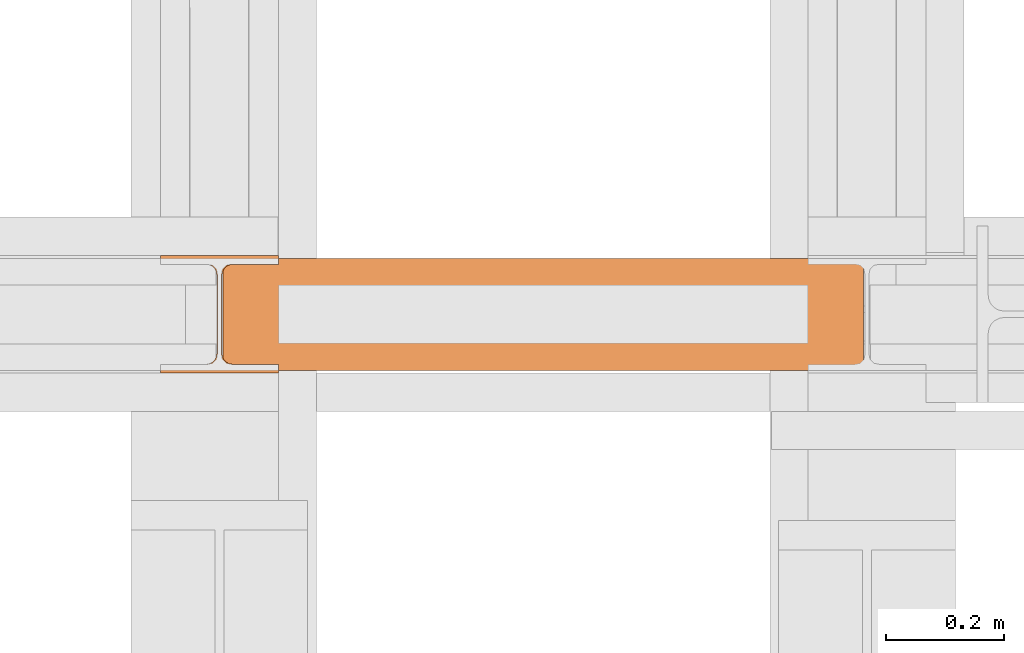
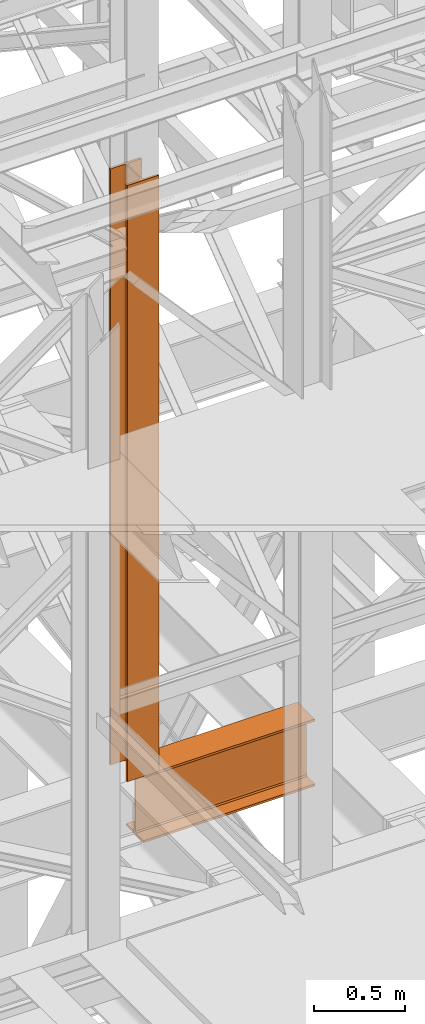
# One storey, part 113 of 208: 2 proxies.
"""IFC2X3 building model written with IfcOpenShell, lengths in millimetres."""

from ifc_helpers import new_model, entity, si_unit, converted_unit, frame, origin, origin_with_axes, place, context, subcontext, project, spatial, faceted_brep, element, save


model = new_model("IFC2X3")

# Units and contexts
model_context = context("Model", 3, precision=1e-05, world=origin())
plan_context = context("Plan", 3, precision=1e-05, world=origin())
body_context = subcontext(model_context, "Body", "Model", "MODEL_VIEW")
ifc_project = project(units=[si_unit("LENGTHUNIT", "METRE", prefix="MILLI"), converted_unit("PLANEANGLEUNIT", "DEGREE", entity("IfcPlaneAngleMeasure", 0.0174532925199433), si_unit("PLANEANGLEUNIT", "RADIAN"), dimensions=[0, 0, 0, 0, 0, 0, 0]), si_unit("AREAUNIT", "SQUARE_METRE"), si_unit("VOLUMEUNIT", "CUBIC_METRE")], contexts=[model_context, plan_context])

# Building, storey
building_placement = place(None, origin())
building = spatial("IfcBuilding", under=ifc_project, at=building_placement, CompositionType="COMPLEX")
storey_placement = place(building_placement, origin_with_axes())
storey = spatial("IfcBuildingStorey", under=building, at=storey_placement, Name="Geschoss", CompositionType="ELEMENT")

# Proxies
proxy_1_placement = place(storey_placement, frame((2199.254968580824, -16057.57439657637, 4834.989987483023), z_axis=(0.0, 0.0, 1.0), x_axis=(1.0, 0.0, 0.0)))
element("IfcBuildingElementProxy", 1, at=proxy_1_placement, inside=storey, context=body_context, shape_type="Brep", body=[
    faceted_brep([(1088.009999895696, 0.01000000000021828, 450.0100178813937), (1088.009999895696, 190.0100125169756, 450.0100178813937), (1088.009999895696, 190.0100125169756, 435.4100240564349), (1088.009999895696, 120.7100073045494, 435.4100091552737), (1088.009999895696, 109.841562265754, 433.2347078418734), (1088.009999895696, 101.8853126263621, 425.2784563398363), (1088.009999895696, 99.71000619068764, 414.4100113010409), (1088.009999895696, 99.71000619068764, 35.60999167919181), (1088.009999895696, 101.8853126263621, 24.74154664039634), (1088.009999895696, 109.841562265754, 16.78529513835929), (1088.009999895696, 120.7100073045494, 14.60999382495902), (1088.009999895696, 190.0100125169756, 14.60999382495902), (1088.009999895696, 190.0100125169756, 0.01000000000021828), (1088.009999895696, 0.01000000000021828, 0.01000000000021828), (1088.009999895696, 0.01000000000021828, 14.60999382495902), (1088.009999895696, 69.3100052124264, 14.60999382495902), (1088.009999895696, 80.17845025122188, 16.78529513835929), (1088.009999895696, 88.13469989061377, 24.74154664039634), (1088.009999895696, 90.3100063262882, 35.60999167919181), (1088.009999895696, 90.3100063262882, 414.4100113010409), (1088.009999895696, 88.13469989061377, 425.2784563398363), (1088.009999895696, 80.17845025122188, 433.2347078418734), (1088.009999895696, 69.3100052124264, 435.4100091552737), (1088.009999895696, 0.01000000000021828, 435.4100240564349), (1088.009999895696, 190.0100125169756, 450.0100178813937), (1088.009999895696, 0.01000000000021828, 450.0100178813937), (0.01000000000021828, 0.01000000000021828, 450.0100178813937), (0.01000000000021828, 190.0100125169756, 450.0100178813937), (1088.009999895696, 190.0100125169756, 435.4100240564349), (1088.009999895696, 190.0100125169756, 450.0100178813937), (0.01000000000021828, 190.0100125169756, 450.0100178813937), (0.01000000000021828, 190.0100125169756, 435.4100240564349), (1088.009999895696, 120.7100073045494, 435.4100091552737), (1088.009999895696, 190.0100125169756, 435.4100240564349), (0.01000000000021828, 190.0100125169756, 435.4100240564349), (0.01000000000021828, 120.7100073045494, 435.4100091552737), (1088.009999895696, 109.841562265754, 433.2347078418734), (1088.009999895696, 120.7100073045494, 435.4100091552737), (0.01000000000021828, 120.7100073045494, 435.4100091552737), (0.01000000000021828, 109.841562265754, 433.2347078418734), (1088.009999895696, 101.8853126263621, 425.2784563398363), (1088.009999895696, 109.841562265754, 433.2347078418734), (0.01000000000021828, 109.841562265754, 433.2347078418734), (0.01000000000021828, 101.8853126263621, 425.2784563398363), (1088.009999895696, 99.71000619068764, 414.4100113010409), (1088.009999895696, 101.8853126263621, 425.2784563398363), (0.01000000000021828, 101.8853126263621, 425.2784563398363), (0.01000000000021828, 99.71000619068764, 414.4100113010409), (1088.009999895696, 99.71000619068764, 35.60999167919181), (1088.009999895696, 99.71000619068764, 414.4100113010409), (0.01000000000021828, 99.71000619068764, 414.4100113010409), (0.01000000000021828, 99.71000619068764, 35.60999167919181), (1088.009999895696, 101.8853126263621, 24.74154664039634), (1088.009999895696, 99.71000619068764, 35.60999167919181), (0.01000000000021828, 99.71000619068764, 35.60999167919181), (0.01000000000021828, 101.8853126263621, 24.74154664039634), (1088.009999895696, 109.841562265754, 16.78529513835929), (1088.009999895696, 101.8853126263621, 24.74154664039634), (0.01000000000021828, 101.8853126263621, 24.74154664039634), (0.01000000000021828, 109.841562265754, 16.78529513835929), (1088.009999895696, 120.7100073045494, 14.60999382495902), (1088.009999895696, 109.841562265754, 16.78529513835929), (0.01000000000021828, 109.841562265754, 16.78529513835929), (0.01000000000021828, 120.7100073045494, 14.60999382495902), (1088.009999895696, 190.0100125169756, 14.60999382495902), (1088.009999895696, 120.7100073045494, 14.60999382495902), (0.01000000000021828, 120.7100073045494, 14.60999382495902), (0.01000000000021828, 190.0100125169756, 14.60999382495902), (1088.009999895696, 190.0100125169756, 0.01000000000021828), (1088.009999895696, 190.0100125169756, 14.60999382495902), (0.01000000000021828, 190.0100125169756, 14.60999382495902), (0.01000000000021828, 190.0100125169756, 0.01000000000021828), (1088.009999895696, 0.01000000000021828, 0.01000000000021828), (1088.009999895696, 190.0100125169756, 0.01000000000021828), (0.01000000000021828, 190.0100125169756, 0.01000000000021828), (0.01000000000021828, 0.01000000000021828, 0.01000000000021828), (1088.009999895696, 0.01000000000021828, 14.60999382495902), (1088.009999895696, 0.01000000000021828, 0.01000000000021828), (0.01000000000021828, 0.01000000000021828, 0.01000000000021828), (0.01000000000021828, 0.01000000000021828, 14.60999382495902), (1088.009999895696, 69.3100052124264, 14.60999382495902), (1088.009999895696, 0.01000000000021828, 14.60999382495902), (0.01000000000021828, 0.01000000000021828, 14.60999382495902), (0.01000000000021828, 69.3100052124264, 14.60999382495902), (1088.009999895696, 80.17845025122188, 16.78529513835929), (1088.009999895696, 69.3100052124264, 14.60999382495902), (0.01000000000021828, 69.3100052124264, 14.60999382495902), (0.01000000000021828, 80.17845025122188, 16.78529513835929), (1088.009999895696, 88.13469989061377, 24.74154664039634), (1088.009999895696, 80.17845025122188, 16.78529513835929), (0.01000000000021828, 80.17845025122188, 16.78529513835929), (0.01000000000021828, 88.13469989061377, 24.74154664039634), (1088.009999895696, 90.3100063262882, 35.60999167919181), (1088.009999895696, 88.13469989061377, 24.74154664039634), (0.01000000000021828, 88.13469989061377, 24.74154664039634), (0.01000000000021828, 90.3100063262882, 35.60999167919181), (1088.009999895696, 90.3100063262882, 414.4100113010409), (1088.009999895696, 90.3100063262882, 35.60999167919181), (0.01000000000021828, 90.3100063262882, 35.60999167919181), (0.01000000000021828, 90.3100063262882, 414.4100113010409), (1088.009999895696, 88.13469989061377, 425.2784563398363), (1088.009999895696, 90.3100063262882, 414.4100113010409), (0.01000000000021828, 90.3100063262882, 414.4100113010409), (0.01000000000021828, 88.13469989061377, 425.2784563398363), (1088.009999895696, 80.17845025122188, 433.2347078418734), (1088.009999895696, 88.13469989061377, 425.2784563398363), (0.01000000000021828, 88.13469989061377, 425.2784563398363), (0.01000000000021828, 80.17845025122188, 433.2347078418734), (1088.009999895696, 69.3100052124264, 435.4100091552737), (1088.009999895696, 80.17845025122188, 433.2347078418734), (0.01000000000021828, 80.17845025122188, 433.2347078418734), (0.01000000000021828, 69.3100052124264, 435.4100091552737), (1088.009999895696, 0.01000000000021828, 435.4100240564349), (1088.009999895696, 69.3100052124264, 435.4100091552737), (0.01000000000021828, 69.3100052124264, 435.4100091552737), (0.01000000000021828, 0.01000000000021828, 435.4100240564349), (1088.009999895696, 0.01000000000021828, 450.0100178813937), (1088.009999895696, 0.01000000000021828, 435.4100240564349), (0.01000000000021828, 0.01000000000021828, 435.4100240564349), (0.01000000000021828, 0.01000000000021828, 450.0100178813937), (0.01000000000021828, 0.01000000000021828, 450.0100178813937), (0.01000000000021828, 0.01000000000021828, 435.4100240564349), (0.01000000000021828, 69.3100052124264, 435.4100091552737), (0.01000000000021828, 80.17845025122188, 433.2347078418734), (0.01000000000021828, 88.13469989061377, 425.2784563398363), (0.01000000000021828, 90.3100063262882, 414.4100113010409), (0.01000000000021828, 90.3100063262882, 35.60999167919181), (0.01000000000021828, 88.13469989061377, 24.74154664039634), (0.01000000000021828, 80.17845025122188, 16.78529513835929), (0.01000000000021828, 69.3100052124264, 14.60999382495902), (0.01000000000021828, 0.01000000000021828, 14.60999382495902), (0.01000000000021828, 0.01000000000021828, 0.01000000000021828), (0.01000000000021828, 190.0100125169756, 0.01000000000021828), (0.01000000000021828, 190.0100125169756, 14.60999382495902), (0.01000000000021828, 120.7100073045494, 14.60999382495902), (0.01000000000021828, 109.841562265754, 16.78529513835929), (0.01000000000021828, 101.8853126263621, 24.74154664039634), (0.01000000000021828, 99.71000619068764, 35.60999167919181), (0.01000000000021828, 99.71000619068764, 414.4100113010409), (0.01000000000021828, 101.8853126263621, 425.2784563398363), (0.01000000000021828, 109.841562265754, 433.2347078418734), (0.01000000000021828, 120.7100073045494, 435.4100091552737), (0.01000000000021828, 190.0100125169756, 435.4100240564349), (0.01000000000021828, 190.0100125169756, 450.0100178813937)], [[[0, 1, 2, 3, 4, 5, 6, 7, 8, 9, 10, 11, 12, 13, 14, 15, 16, 17, 18, 19, 20, 21, 22, 23]], [[24, 25, 26, 27]], [[28, 29, 30, 31]], [[32, 33, 34, 35]], [[36, 37, 38, 39]], [[40, 41, 42, 43]], [[44, 45, 46, 47]], [[48, 49, 50, 51]], [[52, 53, 54, 55]], [[56, 57, 58, 59]], [[60, 61, 62, 63]], [[64, 65, 66, 67]], [[68, 69, 70, 71]], [[72, 73, 74, 75]], [[76, 77, 78, 79]], [[80, 81, 82, 83]], [[84, 85, 86, 87]], [[88, 89, 90, 91]], [[92, 93, 94, 95]], [[96, 97, 98, 99]], [[100, 101, 102, 103]], [[104, 105, 106, 107]], [[108, 109, 110, 111]], [[112, 113, 114, 115]], [[116, 117, 118, 119]], [[120, 121, 122, 123, 124, 125, 126, 127, 128, 129, 130, 131, 132, 133, 134, 135, 136, 137, 138, 139, 140, 141, 142, 143]]], orient=[[False], [False], [False], [False], [False], [False], [False], [False], [False], [False], [False], [False], [False], [False], [False], [False], [False], [False], [False], [False], [False], [False], [False], [False], [False], [False]]),
])
proxy_2_placement = place(storey_placement, frame((2093.254968528665, -16062.57439031789, 5284.990005364414), z_axis=(0.0, 0.0, 1.0), x_axis=(1.0, 0.0, 0.0)))
element("IfcBuildingElementProxy", 2, at=proxy_2_placement, inside=storey, Name="3D Element", context=body_context, shape_type="Brep", body=[
    faceted_brep([(0.01000000000021828, 15.01000000000022, 0.01000000000021828), (0.01000000000021828, 0.01000000000021828, 0.01000000000021828), (200.0100000000002, 0.01000000000021828, 0.01000000000021828), (200.0100000000002, 15.01000000000022, 0.01000000000021828), (122.5100000000002, 15.01000000000022, 0.01000000000021828), (116.9477129694265, 15.8910440384916, 0.01000000000021828), (111.9298832894656, 18.44771635773031, 0.01000000000021828), (107.9477163577321, 22.42988328946558, 0.01000000000021828), (105.3910440384934, 27.44771296942599, 0.01000000000021828), (104.5100000000002, 33.01000000000022, 0.01000000000021828), (104.5100000000002, 167.0100000000002, 0.01000000000021828), (105.6055874411059, 172.9933586889038, 0.01000000000021828), (107.9477163577321, 177.5901167105349, 0.01000000000021828), (111.9298832894656, 181.5722836422665, 0.01000000000021828), (116.9477129694265, 184.1289559615052, 0.01000000000021828), (122.5100000000002, 185.0100000000002, 0.01000000000021828), (200.0100000000002, 185.0100000000002, 0.01000000000021828), (200.0100000000002, 200.0100000000002, 0.01000000000021828), (0.01000000000021828, 200.0100000000002, 0.01000000000021828), (0.01000000000021828, 185.0100000000002, 0.01000000000021828), (77.51000000000022, 185.0100000000002, 0.01000000000021828), (83.07228703057353, 184.1289559615052, 0.01000000000021828), (88.0901167105344, 181.5722836422665, 0.01000000000021828), (92.07228364226785, 177.5901167105349, 0.01000000000021828), (94.62895596150656, 172.5722870305744, 0.01000000000021828), (95.51000000000022, 167.0100000000002, 0.01000000000021828), (95.51000000000022, 33.01000000000022, 0.01000000000021828), (94.62895596150656, 27.44771296942599, 0.01000000000021828), (92.07228364226785, 22.42988328946558, 0.01000000000021828), (88.0901167105344, 18.44771635773031, 0.01000000000021828), (83.07228703057353, 15.8910440384916, 0.01000000000021828), (77.51000000000022, 15.01000000000022, 0.01000000000021828), (0.01000000000021828, 0.01000000000021828, 0.01000000000021828), (0.01000000000021828, 15.01000000000022, 0.01000000000021828), (0.01000000000021828, 15.01000000000022, 4000.01), (0.01000000000021828, 0.01000000000021828, 4000.01), (200.0100000000002, 0.01000000000021828, 0.01000000000021828), (0.01000000000021828, 0.01000000000021828, 0.01000000000021828), (0.01000000000021828, 0.01000000000021828, 4000.01), (200.0100000000002, 0.01000000000021828, 4000.01), (200.0100000000002, 15.01000000000022, 0.01000000000021828), (200.0100000000002, 0.01000000000021828, 0.01000000000021828), (200.0100000000002, 0.01000000000021828, 4000.01), (200.0100000000002, 15.01000000000022, 4000.01), (122.5100000000002, 15.01000000000022, 0.01000000000021828), (200.0100000000002, 15.01000000000022, 0.01000000000021828), (200.0100000000002, 15.01000000000022, 4000.01), (122.5100000000002, 15.01000000000022, 4000.01), (116.9477129694265, 15.8910440384916, 0.01000000000021828), (122.5100000000002, 15.01000000000022, 0.01000000000021828), (122.5100000000002, 15.01000000000022, 4000.01), (116.9477129694265, 15.8910440384916, 4000.01), (111.9298832894656, 18.44771635773031, 0.01000000000021828), (116.9477129694265, 15.8910440384916, 0.01000000000021828), (116.9477129694265, 15.8910440384916, 4000.01), (111.9298832894656, 18.44771635773031, 4000.01), (107.9477163577321, 22.42988328946558, 0.01000000000021828), (111.9298832894656, 18.44771635773031, 0.01000000000021828), (111.9298832894656, 18.44771635773031, 4000.01), (107.9477163577321, 22.42988328946558, 4000.01), (105.3910440384934, 27.44771296942599, 0.01000000000021828), (107.9477163577321, 22.42988328946558, 0.01000000000021828), (107.9477163577321, 22.42988328946558, 4000.01), (105.3910440384934, 27.44771296942599, 4000.01), (104.5100000000002, 33.01000000000022, 0.01000000000021828), (105.3910440384934, 27.44771296942599, 0.01000000000021828), (105.3910440384934, 27.44771296942599, 4000.01), (104.5100000000002, 33.01000000000022, 4000.01), (104.5100000000002, 167.0100000000002, 0.01000000000021828), (104.5100000000002, 33.01000000000022, 0.01000000000021828), (104.5100000000002, 33.01000000000022, 4000.01), (104.5100000000002, 167.0100000000002, 4000.01), (105.6055874411059, 172.9933586889038, 0.01000000000021828), (104.5100000000002, 167.0100000000002, 0.01000000000021828), (104.5100000000002, 167.0100000000002, 4000.01), (105.6055874411059, 172.9933586889038, 4000.01), (107.9477163577321, 177.5901167105349, 0.01000000000021828), (105.6055874411059, 172.9933586889038, 0.01000000000021828), (105.6055874411059, 172.9933586889038, 4000.01), (107.9477163577321, 177.5901167105349, 4000.01), (111.9298832894656, 181.5722836422665, 0.01000000000021828), (107.9477163577321, 177.5901167105349, 0.01000000000021828), (107.9477163577321, 177.5901167105349, 4000.01), (111.9298832894656, 181.5722836422665, 4000.01), (116.9477129694265, 184.1289559615052, 0.01000000000021828), (111.9298832894656, 181.5722836422665, 0.01000000000021828), (111.9298832894656, 181.5722836422665, 4000.01), (116.9477129694265, 184.1289559615052, 4000.01), (122.5100000000002, 185.0100000000002, 0.01000000000021828), (116.9477129694265, 184.1289559615052, 0.01000000000021828), (116.9477129694265, 184.1289559615052, 4000.01), (122.5100000000002, 185.0100000000002, 4000.01), (200.0100000000002, 185.0100000000002, 0.01000000000021828), (122.5100000000002, 185.0100000000002, 0.01000000000021828), (122.5100000000002, 185.0100000000002, 4000.01), (200.0100000000002, 185.0100000000002, 4000.01), (200.0100000000002, 200.0100000000002, 0.01000000000021828), (200.0100000000002, 185.0100000000002, 0.01000000000021828), (200.0100000000002, 185.0100000000002, 4000.01), (200.0100000000002, 200.0100000000002, 4000.01), (0.01000000000021828, 200.0100000000002, 0.01000000000021828), (200.0100000000002, 200.0100000000002, 0.01000000000021828), (200.0100000000002, 200.0100000000002, 4000.01), (0.01000000000021828, 200.0100000000002, 4000.01), (0.01000000000021828, 185.0100000000002, 0.01000000000021828), (0.01000000000021828, 200.0100000000002, 0.01000000000021828), (0.01000000000021828, 200.0100000000002, 4000.01), (0.01000000000021828, 185.0100000000002, 4000.01), (77.51000000000022, 185.0100000000002, 0.01000000000021828), (0.01000000000021828, 185.0100000000002, 0.01000000000021828), (0.01000000000021828, 185.0100000000002, 4000.01), (77.51000000000022, 185.0100000000002, 4000.01), (83.07228703057353, 184.1289559615052, 0.01000000000021828), (77.51000000000022, 185.0100000000002, 0.01000000000021828), (77.51000000000022, 185.0100000000002, 4000.01), (83.07228703057353, 184.1289559615052, 4000.01), (88.0901167105344, 181.5722836422665, 0.01000000000021828), (83.07228703057353, 184.1289559615052, 0.01000000000021828), (83.07228703057353, 184.1289559615052, 4000.01), (88.0901167105344, 181.5722836422665, 4000.01), (92.07228364226785, 177.5901167105349, 0.01000000000021828), (88.0901167105344, 181.5722836422665, 0.01000000000021828), (88.0901167105344, 181.5722836422665, 4000.01), (92.07228364226785, 177.5901167105349, 4000.01), (94.62895596150656, 172.5722870305744, 0.01000000000021828), (92.07228364226785, 177.5901167105349, 0.01000000000021828), (92.07228364226785, 177.5901167105349, 4000.01), (94.62895596150656, 172.5722870305744, 4000.01), (95.51000000000022, 167.0100000000002, 0.01000000000021828), (94.62895596150656, 172.5722870305744, 0.01000000000021828), (94.62895596150656, 172.5722870305744, 4000.01), (95.51000000000022, 167.0100000000002, 4000.01), (95.51000000000022, 33.01000000000022, 0.01000000000021828), (95.51000000000022, 167.0100000000002, 0.01000000000021828), (95.51000000000022, 167.0100000000002, 4000.01), (95.51000000000022, 33.01000000000022, 4000.01), (94.62895596150656, 27.44771296942599, 0.01000000000021828), (95.51000000000022, 33.01000000000022, 0.01000000000021828), (95.51000000000022, 33.01000000000022, 4000.01), (94.62895596150656, 27.44771296942599, 4000.01), (92.07228364226785, 22.42988328946558, 0.01000000000021828), (94.62895596150656, 27.44771296942599, 0.01000000000021828), (94.62895596150656, 27.44771296942599, 4000.01), (92.07228364226785, 22.42988328946558, 4000.01), (88.0901167105344, 18.44771635773031, 0.01000000000021828), (92.07228364226785, 22.42988328946558, 0.01000000000021828), (92.07228364226785, 22.42988328946558, 4000.01), (88.0901167105344, 18.44771635773031, 4000.01), (83.07228703057353, 15.8910440384916, 0.01000000000021828), (88.0901167105344, 18.44771635773031, 0.01000000000021828), (88.0901167105344, 18.44771635773031, 4000.01), (83.07228703057353, 15.8910440384916, 4000.01), (77.51000000000022, 15.01000000000022, 0.01000000000021828), (83.07228703057353, 15.8910440384916, 0.01000000000021828), (83.07228703057353, 15.8910440384916, 4000.01), (77.51000000000022, 15.01000000000022, 4000.01), (0.01000000000021828, 15.01000000000022, 0.01000000000021828), (77.51000000000022, 15.01000000000022, 0.01000000000021828), (77.51000000000022, 15.01000000000022, 4000.01), (0.01000000000021828, 15.01000000000022, 4000.01), (0.01000000000021828, 15.01000000000022, 4000.01), (77.51000000000022, 15.01000000000022, 4000.01), (83.07228703057353, 15.8910440384916, 4000.01), (88.0901167105344, 18.44771635773031, 4000.01), (92.07228364226785, 22.42988328946558, 4000.01), (94.62895596150656, 27.44771296942599, 4000.01), (95.51000000000022, 33.01000000000022, 4000.01), (95.51000000000022, 167.0100000000002, 4000.01), (94.62895596150656, 172.5722870305744, 4000.01), (92.07228364226785, 177.5901167105349, 4000.01), (88.0901167105344, 181.5722836422665, 4000.01), (83.07228703057353, 184.1289559615052, 4000.01), (77.51000000000022, 185.0100000000002, 4000.01), (0.01000000000021828, 185.0100000000002, 4000.01), (0.01000000000021828, 200.0100000000002, 4000.01), (200.0100000000002, 200.0100000000002, 4000.01), (200.0100000000002, 185.0100000000002, 4000.01), (122.5100000000002, 185.0100000000002, 4000.01), (116.9477129694265, 184.1289559615052, 4000.01), (111.9298832894656, 181.5722836422665, 4000.01), (107.9477163577321, 177.5901167105349, 4000.01), (105.6055874411059, 172.9933586889038, 4000.01), (104.5100000000002, 167.0100000000002, 4000.01), (104.5100000000002, 33.01000000000022, 4000.01), (105.3910440384934, 27.44771296942599, 4000.01), (107.9477163577321, 22.42988328946558, 4000.01), (111.9298832894656, 18.44771635773031, 4000.01), (116.9477129694265, 15.8910440384916, 4000.01), (122.5100000000002, 15.01000000000022, 4000.01), (200.0100000000002, 15.01000000000022, 4000.01), (200.0100000000002, 0.01000000000021828, 4000.01), (0.01000000000021828, 0.01000000000021828, 4000.01)], [[[0, 1, 2, 3, 4, 5, 6, 7, 8, 9, 10, 11, 12, 13, 14, 15, 16, 17, 18, 19, 20, 21, 22, 23, 24, 25, 26, 27, 28, 29, 30, 31]], [[32, 33, 34, 35]], [[36, 37, 38, 39]], [[40, 41, 42, 43]], [[44, 45, 46, 47]], [[48, 49, 50, 51]], [[52, 53, 54, 55]], [[56, 57, 58, 59]], [[60, 61, 62, 63]], [[64, 65, 66, 67]], [[68, 69, 70, 71]], [[72, 73, 74, 75]], [[76, 77, 78, 79]], [[80, 81, 82, 83]], [[84, 85, 86, 87]], [[88, 89, 90, 91]], [[92, 93, 94, 95]], [[96, 97, 98, 99]], [[100, 101, 102, 103]], [[104, 105, 106, 107]], [[108, 109, 110, 111]], [[112, 113, 114, 115]], [[116, 117, 118, 119]], [[120, 121, 122, 123]], [[124, 125, 126, 127]], [[128, 129, 130, 131]], [[132, 133, 134, 135]], [[136, 137, 138, 139]], [[140, 141, 142, 143]], [[144, 145, 146, 147]], [[148, 149, 150, 151]], [[152, 153, 154, 155]], [[156, 157, 158, 159]], [[160, 161, 162, 163, 164, 165, 166, 167, 168, 169, 170, 171, 172, 173, 174, 175, 176, 177, 178, 179, 180, 181, 182, 183, 184, 185, 186, 187, 188, 189, 190, 191]]], orient=[[False], [False], [False], [False], [False], [False], [False], [False], [False], [False], [False], [False], [False], [False], [False], [False], [False], [False], [False], [False], [False], [False], [False], [False], [False], [False], [False], [False], [False], [False], [False], [False], [False], [False]]),
])

save(model, "model.ifc")
